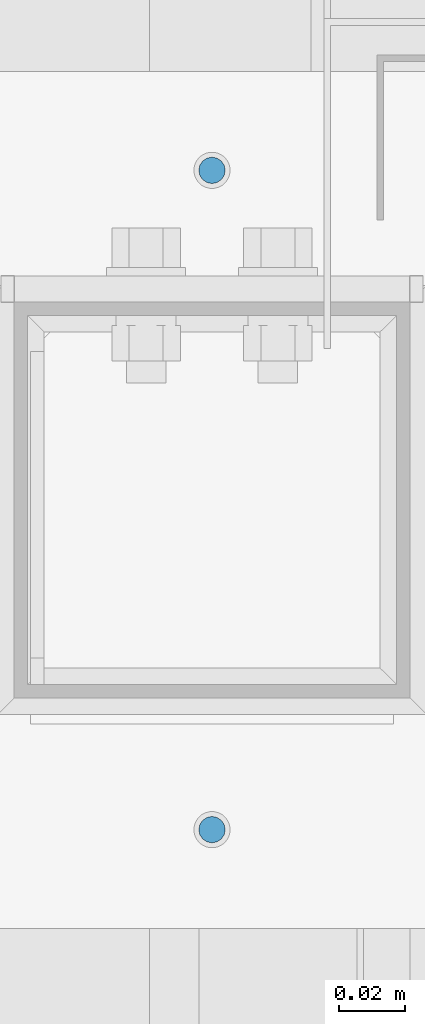
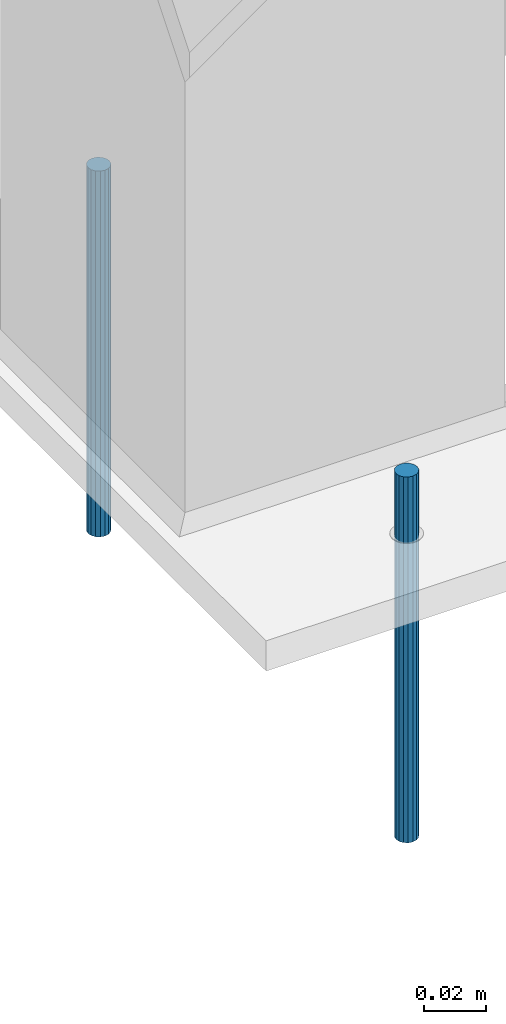
# One storey, part 99 of 709: 2 beams, 2 elements without a shape of their own.
"""IFC4 building model written with IfcOpenShell, lengths in millimetres."""

from ifc_helpers import new_model, si_unit, direction, frame, origin_with_axes, place, context, subcontext, project, spatial, line, indexed_curve, outline, extrude, material, element, aggregate, save


model = new_model("IFC4")

# Units and contexts
model_context = context("Model", 3, precision=0.2, world=origin_with_axes(), true_north=direction((0.0, 1.0)))
body_context = subcontext(model_context, "Body", "Model", "MODEL_VIEW")
ifc_project = project(units=[si_unit("LENGTHUNIT", "METRE", prefix="MILLI"), si_unit("AREAUNIT", "SQUARE_METRE"), si_unit("VOLUMEUNIT", "CUBIC_METRE"), si_unit("MASSUNIT", "GRAM", prefix="KILO"), si_unit("TIMEUNIT", "SECOND"), si_unit("PLANEANGLEUNIT", "RADIAN"), si_unit("SOLIDANGLEUNIT", "STERADIAN"), si_unit("THERMODYNAMICTEMPERATUREUNIT", "DEGREE_CELSIUS"), si_unit("LUMINOUSINTENSITYUNIT", "LUMEN")], contexts=[model_context])

# Site, building, storey
site_placement = place(None, origin_with_axes())
site = spatial("IfcSite", under=ifc_project, at=site_placement, CompositionType="ELEMENT")
building_placement = place(site_placement, origin_with_axes())
building = spatial("IfcBuilding", under=site, at=building_placement, Name="Undefined", CompositionType="ELEMENT")
storey_placement = place(building_placement, origin_with_axes())
storey = spatial("IfcBuildingStorey", under=building, at=storey_placement, Name="Undefined", CompositionType="ELEMENT", Elevation=0.0)

# Assembly, beam
assembly_1_placement = place(storey_placement, frame((49940.0, 860.0, -13.0), z_axis=(0.0, 1.0, 0.0), x_axis=(0.0, 0.0, -1.0)))
assembly_1 = element("IfcElementAssembly", 1, at=assembly_1_placement, inside=storey)
ifc_material = material(Name="Steel_Undefined", Category="STEEL")
beam_1_placement = place(assembly_1_placement, origin_with_axes())
beam_1 = element("IfcBeam", 2, at=beam_1_placement, material=ifc_material, context=body_context, shape_type="SolidModel", body=[
    extrude(outline(indexed_curve([(4.0, 0.0), (3.69552, 1.53073), (2.82843, 2.82843), (1.53073, 3.69552), (0.0, 4.0), (-1.53073, 3.69552), (-2.82843, 2.82843), (-3.69552, 1.53073), (-4.0, 0.0), (-3.69552, -1.53073), (-2.82843, -2.82843), (-1.53073, -3.69552), (0.0, -4.0), (1.53073, -3.69552), (2.82843, -2.82843), (3.69552, -1.53073)], segments=[line(1, 2, 3, 4, 5, 6, 7, 8, 9, 10, 11, 12, 13, 14, 15, 16, 1)])), frame((0.0, 0.0, 0.0), z_axis=(-1.0, 0.0, 0.0), x_axis=(0.0, 0.0, 1.0)), (0.0, 0.0, -1.0), 145.0),
])
aggregate(assembly_1, [beam_1])

assembly_2_placement = place(storey_placement, frame((49940.0, 660.0, -13.0), z_axis=(0.0, 1.0, 0.0), x_axis=(0.0, 0.0, -1.0)))
assembly_2 = element("IfcElementAssembly", 3, at=assembly_2_placement, inside=storey)
beam_2_placement = place(assembly_2_placement, origin_with_axes())
beam_2 = element("IfcBeam", 4, at=beam_2_placement, material=ifc_material, context=body_context, shape_type="SolidModel", body=[
    extrude(outline(indexed_curve([(4.0, 0.0), (3.69552, 1.53073), (2.82843, 2.82843), (1.53073, 3.69552), (0.0, 4.0), (-1.53073, 3.69552), (-2.82843, 2.82843), (-3.69552, 1.53073), (-4.0, 0.0), (-3.69552, -1.53073), (-2.82843, -2.82843), (-1.53073, -3.69552), (0.0, -4.0), (1.53073, -3.69552), (2.82843, -2.82843), (3.69552, -1.53073)], segments=[line(1, 2, 3, 4, 5, 6, 7, 8, 9, 10, 11, 12, 13, 14, 15, 16, 1)])), frame((0.0, 0.0, 0.0), z_axis=(-1.0, 0.0, 0.0), x_axis=(0.0, 0.0, 1.0)), (0.0, 0.0, -1.0), 145.0),
])
aggregate(assembly_2, [beam_2])

save(model, "model.ifc")
